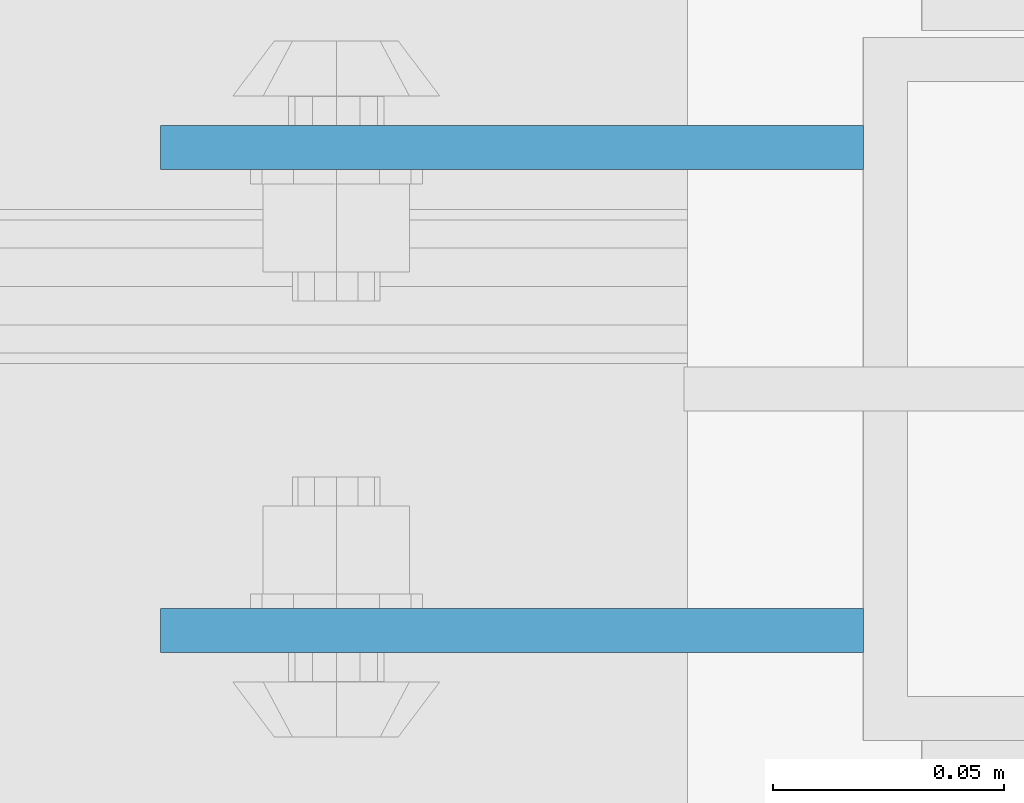
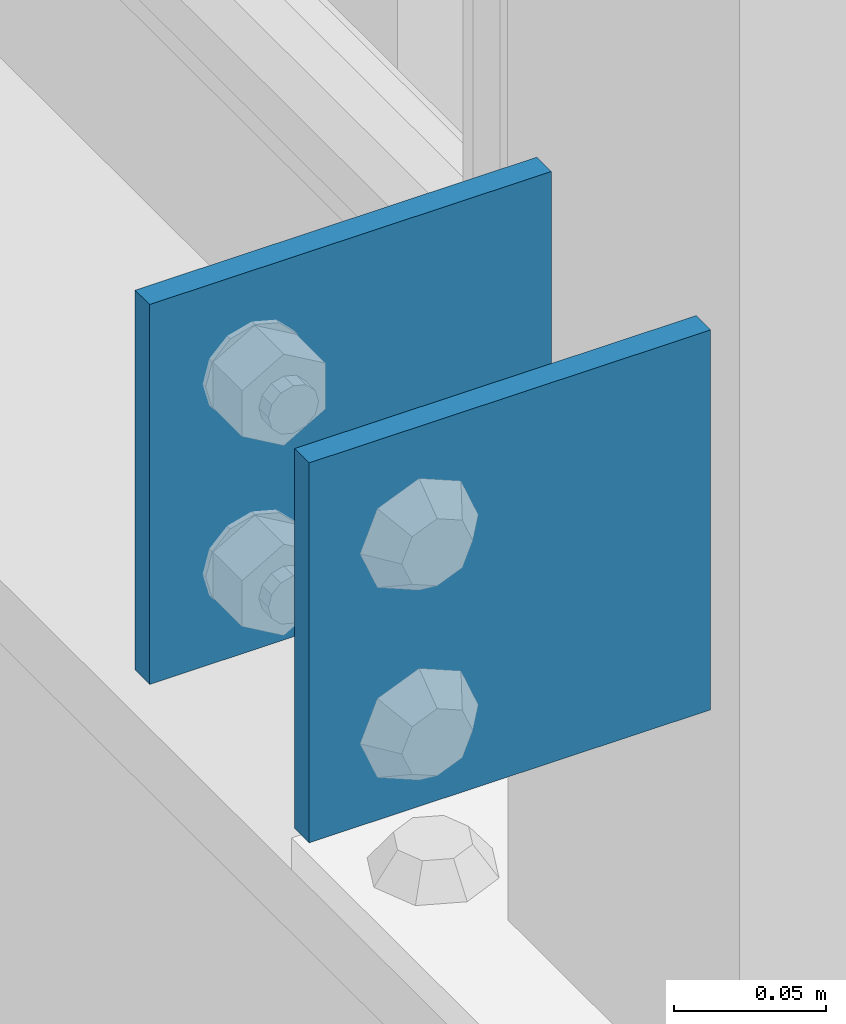
# One storey, part 1298 of 1876: 2 beams, 1 element without a shape of its own.
"""IFC2X3 building model written with IfcOpenShell, lengths in millimetres."""

from ifc_helpers import new_model, si_unit, frame, origin_with_axes, place, context, subcontext, project, spatial, faceted_brep, material, type_object, element, aggregate, save


model = new_model("IFC2X3")

# Units and contexts
model_context = context("Model", 3, precision=1e-05, world=origin_with_axes())
body_context = subcontext(model_context, "Body", "Model", "MODEL_VIEW")
ifc_project = project(units=[si_unit("LENGTHUNIT", "METRE", prefix="MILLI"), si_unit("AREAUNIT", "SQUARE_METRE"), si_unit("VOLUMEUNIT", "CUBIC_METRE"), si_unit("MASSUNIT", "GRAM", prefix="KILO"), si_unit("TIMEUNIT", "SECOND"), si_unit("PLANEANGLEUNIT", "RADIAN"), si_unit("SOLIDANGLEUNIT", "STERADIAN"), si_unit("THERMODYNAMICTEMPERATUREUNIT", "DEGREE_CELSIUS"), si_unit("LUMINOUSINTENSITYUNIT", "LUMEN")], contexts=[model_context])

# Site, building, storey
site_placement = place(None, origin_with_axes())
site = spatial("IfcSite", under=ifc_project, at=site_placement, CompositionType="ELEMENT")
building_placement = place(site_placement, origin_with_axes())
building = spatial("IfcBuilding", under=site, at=building_placement, Name="Undefined", CompositionType="ELEMENT")
storey_placement = place(building_placement, origin_with_axes())
storey = spatial("IfcBuildingStorey", under=building, at=storey_placement, Name="Undefined", CompositionType="ELEMENT", Elevation=0.0)

# Assembly, beams
assembly_placement = place(storey_placement, origin_with_axes())
assembly = element("IfcElementAssembly", 1, at=assembly_placement, inside=storey, Name="BEAM", AssemblyPlace="NOTDEFINED", PredefinedType="RIGID_FRAME")
ifc_material = material(Name="STEEL/A36")
beam_type = type_object("IfcBeamType", PredefinedType="NOTDEFINED")
beam_1_placement = place(assembly_placement, frame((-76.2, 9704.3875, 5384.8), z_axis=(0.0, 0.0, -1.0), x_axis=(-1.0, 0.0, 0.0)))
beam_1 = element("IfcBeam", 2, at=beam_1_placement, type_object=beam_type, material=ifc_material, Name="PLATE", context=body_context, shape_type="Brep", body=[
    faceted_brep([(0.0, 4.76249999999982, -76.1999999999998), (3.63797880709171e-12, 4.76249999999982, 76.1999969482422), (152.399993896484, 4.76250000000073, 76.1999969482422), (152.4, 4.76249999999982, -76.1999999999998), (3.63797880709171e-12, -4.76249999999982, 76.1999969482422), (152.399993896484, -4.76250000000073, 76.1999969482422), (0.0, -4.76249999999982, -76.1999999999998), (152.4, -4.76249999999982, -76.1999999999998)], [[[0, 1, 2, 3]], [[4, 5, 2, 1]], [[4, 6, 7, 5]], [[6, 0, 3, 7]], [[5, 7, 3, 2]], [[6, 4, 1, 0]]]),
])
beam_2_placement = place(assembly_placement, frame((-76.2, 9599.6125, 5384.8), z_axis=(0.0, 0.0, -1.0), x_axis=(-1.0, 0.0, 0.0)))
beam_2 = element("IfcBeam", 3, at=beam_2_placement, type_object=beam_type, material=ifc_material, Name="PLATE", context=body_context, shape_type="Brep", body=[
    faceted_brep([(0.0, 4.76249999999982, -76.1999999999998), (3.63797880709171e-12, 4.76249999999982, 76.1999969482422), (152.399993896484, 4.76250000000073, 76.1999969482422), (152.4, 4.76249999999982, -76.1999999999998), (3.63797880709171e-12, -4.76249999999982, 76.1999969482422), (152.399993896484, -4.76250000000073, 76.1999969482422), (0.0, -4.76249999999982, -76.1999999999998), (152.4, -4.76249999999982, -76.1999999999998)], [[[0, 1, 2, 3]], [[4, 5, 2, 1]], [[4, 6, 7, 5]], [[6, 0, 3, 7]], [[5, 7, 3, 2]], [[6, 4, 1, 0]]]),
])
aggregate(assembly, [beam_1, beam_2])

save(model, "model.ifc")
